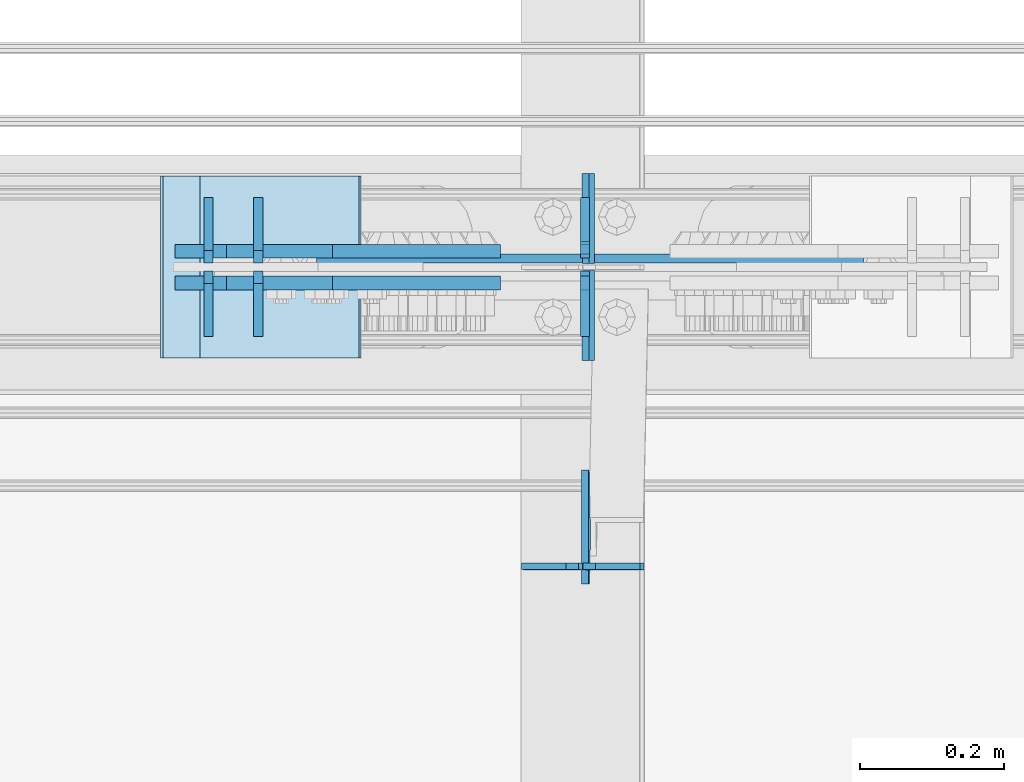
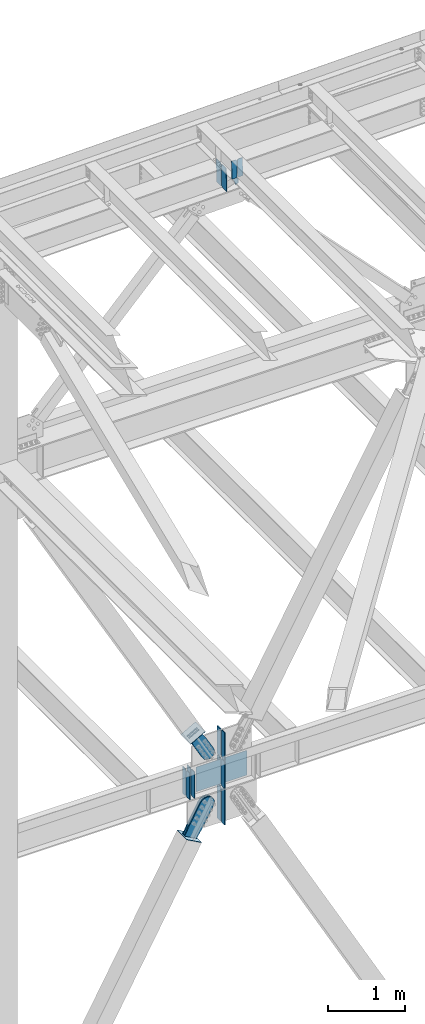
# One storey, part 3482 of 3843: 22 plates, 9 elements without a shape of their own.
"""IFC2X3 building model written with IfcOpenShell, lengths in millimetres."""

from ifc_helpers import new_model, si_unit, frame, origin_with_axes, place, context, subcontext, project, spatial, faceted_brep, material, type_object, element, aggregate, save


model = new_model("IFC2X3")

# Units and contexts
model_context = context("Model", 3, precision=1e-05, world=origin_with_axes())
body_context = subcontext(model_context, "Body", "Model", "MODEL_VIEW")
ifc_project = project(units=[si_unit("LENGTHUNIT", "METRE", prefix="MILLI"), si_unit("AREAUNIT", "SQUARE_METRE"), si_unit("VOLUMEUNIT", "CUBIC_METRE"), si_unit("MASSUNIT", "GRAM", prefix="KILO"), si_unit("TIMEUNIT", "SECOND"), si_unit("PLANEANGLEUNIT", "RADIAN"), si_unit("SOLIDANGLEUNIT", "STERADIAN"), si_unit("THERMODYNAMICTEMPERATUREUNIT", "DEGREE_CELSIUS"), si_unit("LUMINOUSINTENSITYUNIT", "LUMEN")], contexts=[model_context])

# Site, building, storey
site_placement = place(None, origin_with_axes())
site = spatial("IfcSite", under=ifc_project, at=site_placement, CompositionType="ELEMENT")
building_placement = place(site_placement, origin_with_axes())
building = spatial("IfcBuilding", under=site, at=building_placement, Name="Undefined", CompositionType="ELEMENT")
storey_placement = place(building_placement, origin_with_axes())
storey = spatial("IfcBuildingStorey", under=building, at=storey_placement, Name="Undefined", CompositionType="ELEMENT", Elevation=0.0)

# Assembly, plates
assembly_1_placement = place(storey_placement, origin_with_axes())
assembly_1 = element("IfcElementAssembly", 1, at=assembly_1_placement, inside=storey, Name="BEAM", AssemblyPlace="NOTDEFINED", PredefinedType="RIGID_FRAME")
ifc_material_1 = material(Name="STEEL/A572-50")
plate_type_1 = type_object("IfcPlateType", PredefinedType="NOTDEFINED")
plate_1_placement = place(assembly_1_placement, frame((59291.994738493, 92084.525, 45502.009667302), z_axis=(-0.0211520980073474, 0.0, 0.999776269347241), x_axis=(0.0, 1.0, 0.0)))
plate_1 = element("IfcPlate", 2, at=plate_1_placement, type_object=plate_type_1, material=ifc_material_1, Name="STIFFENER", context=body_context, shape_type="Brep", body=[
    faceted_brep([(0.0, -4.76249999999709, 0.0), (0.0, -4.76249999999709, 377.824999997538), (0.0, 4.76249999999709, 377.824999997538), (0.0, 4.76249999999709, 0.0), (103.187499618536, -4.76249999999709, 377.824999997538), (103.187499618536, 4.76249999999709, 377.824999997538), (125.412500000006, -4.76249999999709, 355.599999616068), (125.412500000006, 4.76249999999709, 355.599999616068), (125.412500000006, -4.76249999999709, 22.2250003814697), (125.412500000006, 4.76249999999709, 22.2250003814697), (103.187499618536, -4.76249999999709, 0.0), (103.187499618536, 4.76249999999709, 0.0)], [[[0, 1, 2, 3]], [[1, 4, 5, 2]], [[4, 6, 7, 5]], [[6, 8, 9, 7]], [[8, 10, 11, 9]], [[10, 0, 3, 11]], [[5, 7, 9, 11, 3, 2]], [[10, 8, 6, 4, 1, 0]]]),
])
plate_2_placement = place(assembly_1_placement, frame((59291.994738493, 92219.4625, 45502.009667302), z_axis=(-0.0211520980073474, 0.0, 0.999776269347241), x_axis=(0.0, 1.0, 0.0)))
plate_2 = element("IfcPlate", 3, at=plate_2_placement, type_object=plate_type_1, material=ifc_material_1, Name="STIFFENER", context=body_context, shape_type="Brep", body=[
    faceted_brep([(0.0, -4.76249999999709, 22.2250003814697), (0.0, -4.76249999999709, 355.599999616068), (0.0, 4.76249999999709, 355.599999616068), (0.0, 4.76249999999709, 22.2250003814697), (22.2250003814697, -4.76249999999709, 377.824999997538), (22.2250003814697, 4.76249999999709, 377.824999997538), (125.412500000006, -4.76249999999709, 377.824999997538), (125.412500000006, 4.76249999999709, 377.824999997538), (125.412500000006, -4.76249999999709, 0.0), (125.412500000006, 4.76249999999709, 0.0), (22.2250003814697, -4.76249999999709, 0.0), (22.2250003814697, 4.76249999999709, 0.0)], [[[0, 1, 2, 3]], [[1, 4, 5, 2]], [[4, 6, 7, 5]], [[6, 8, 9, 7]], [[8, 10, 11, 9]], [[10, 0, 3, 11]], [[5, 7, 9, 11, 3, 2]], [[10, 8, 6, 4, 1, 0]]]),
])
aggregate(assembly_1, [plate_1, plate_2])

assembly_2_placement = place(storey_placement, origin_with_axes())
assembly_2 = element("IfcElementAssembly", 4, at=assembly_2_placement, inside=storey, Name="BEAM", AssemblyPlace="NOTDEFINED", PredefinedType="RIGID_FRAME")
plate_type_2 = type_object("IfcPlateType", PredefinedType="NOTDEFINED")
plate_3_placement = place(assembly_2_placement, frame((58758.8797832198, 92220.25625, 35990.2125), z_axis=(0.0, 1.0, 0.0), x_axis=(0.0, 0.0, 1.0)))
plate_3 = element("IfcPlate", 5, at=plate_3_placement, type_object=plate_type_2, material=ifc_material_1, Name="CB_BEAM", context=body_context, shape_type="Brep", body=[
    faceted_brep([(0.0, -6.34999999999854, 17.4624996185303), (0.0, -6.34999999999854, 91.28125), (0.0, 6.34999999999854, 91.28125), (0.0, 6.34999999999854, 17.4624996185303), (425.449999999997, -6.34999999999854, 91.28125), (425.449999999997, 6.34999999999854, 91.28125), (425.449999999997, -6.34999999999854, 17.4624996185303), (425.449999999997, 6.34999999999854, 17.4624996185303), (407.987500381467, -6.34999999999854, 0.0), (407.987500381467, 6.34999999999854, 0.0), (17.4624996185303, -6.34999999999854, 0.0), (17.4624996185303, 6.34999999999854, 0.0)], [[[0, 1, 2, 3]], [[1, 4, 5, 2]], [[4, 6, 7, 5]], [[6, 8, 9, 7]], [[8, 10, 11, 9]], [[10, 0, 3, 11]], [[5, 7, 9, 11, 3, 2]], [[10, 8, 6, 4, 1, 0]]]),
])
plate_4_placement = place(assembly_2_placement, frame((58758.8797832198, 92209.14375, 35990.2125), z_axis=(0.0, -1.0, 0.0), x_axis=(0.0, 0.0, 1.0)))
plate_4 = element("IfcPlate", 6, at=plate_4_placement, type_object=plate_type_2, material=ifc_material_1, Name="CB_BEAM", context=body_context, shape_type="Brep", body=[
    faceted_brep([(0.0, -6.34999999999854, 17.4624996185303), (0.0, -6.34999999999854, 91.28125), (0.0, 6.34999999999854, 91.28125), (0.0, 6.34999999999854, 17.4624996185303), (425.449999999997, -6.34999999999854, 91.28125), (425.449999999997, 6.34999999999854, 91.28125), (425.449999999997, -6.34999999999854, 17.4624996185303), (425.449999999997, 6.34999999999854, 17.4624996185303), (407.987500381467, -6.34999999999854, 0.0), (407.987500381467, 6.34999999999854, 0.0), (17.4624996185303, -6.34999999999854, 0.0), (17.4624996185303, 6.34999999999854, 0.0)], [[[0, 1, 2, 3]], [[1, 4, 5, 2]], [[4, 6, 7, 5]], [[6, 8, 9, 7]], [[8, 10, 11, 9]], [[10, 0, 3, 11]], [[5, 7, 9, 11, 3, 2]], [[10, 8, 6, 4, 1, 0]]]),
])
plate_5_placement = place(assembly_2_placement, frame((58828.0666674803, 92220.25625, 35990.2125), z_axis=(0.0, 1.0, 0.0), x_axis=(0.0, 0.0, 1.0)))
plate_5 = element("IfcPlate", 7, at=plate_5_placement, type_object=plate_type_2, material=ifc_material_1, Name="CB_BEAM", context=body_context, shape_type="Brep", body=[
    faceted_brep([(0.0, -6.34999999999854, 17.4624996185303), (0.0, -6.34999999999854, 91.28125), (0.0, 6.34999999999854, 91.28125), (0.0, 6.34999999999854, 17.4624996185303), (425.449999999997, -6.34999999999854, 91.28125), (425.449999999997, 6.34999999999854, 91.28125), (425.449999999997, -6.34999999999854, 17.4624996185303), (425.449999999997, 6.34999999999854, 17.4624996185303), (407.987500381467, -6.34999999999854, 0.0), (407.987500381467, 6.34999999999854, 0.0), (17.4624996185303, -6.34999999999854, 0.0), (17.4624996185303, 6.34999999999854, 0.0)], [[[0, 1, 2, 3]], [[1, 4, 5, 2]], [[4, 6, 7, 5]], [[6, 8, 9, 7]], [[8, 10, 11, 9]], [[10, 0, 3, 11]], [[5, 7, 9, 11, 3, 2]], [[10, 8, 6, 4, 1, 0]]]),
])
plate_6_placement = place(assembly_2_placement, frame((58828.0666674803, 92209.14375, 35990.2125), z_axis=(0.0, -1.0, 0.0), x_axis=(0.0, 0.0, 1.0)))
plate_6 = element("IfcPlate", 8, at=plate_6_placement, type_object=plate_type_2, material=ifc_material_1, Name="CB_BEAM", context=body_context, shape_type="Brep", body=[
    faceted_brep([(0.0, -6.34999999999854, 17.4624996185303), (0.0, -6.34999999999854, 91.28125), (0.0, 6.34999999999854, 91.28125), (0.0, 6.34999999999854, 17.4624996185303), (425.449999999997, -6.34999999999854, 91.28125), (425.449999999997, 6.34999999999854, 91.28125), (425.449999999997, -6.34999999999854, 17.4624996185303), (425.449999999997, 6.34999999999854, 17.4624996185303), (407.987500381467, -6.34999999999854, 0.0), (407.987500381467, 6.34999999999854, 0.0), (17.4624996185303, -6.34999999999854, 0.0), (17.4624996185303, 6.34999999999854, 0.0)], [[[0, 1, 2, 3]], [[1, 4, 5, 2]], [[4, 6, 7, 5]], [[6, 8, 9, 7]], [[8, 10, 11, 9]], [[10, 0, 3, 11]], [[5, 7, 9, 11, 3, 2]], [[10, 8, 6, 4, 1, 0]]]),
])
plate_7_placement = place(assembly_2_placement, frame((59283.6000023894, 92209.14375, 35990.2125), z_axis=(0.0, -1.0, 0.0), x_axis=(0.0, 0.0, 1.0)))
plate_7 = element("IfcPlate", 9, at=plate_7_placement, type_object=plate_type_2, material=ifc_material_1, Name="CB_BEAM", context=body_context, shape_type="Brep", body=[
    faceted_brep([(0.0, -6.34999999999854, 17.4624996185303), (0.0, -6.34999999999854, 91.28125), (0.0, 6.34999999999854, 91.28125), (0.0, 6.34999999999854, 17.4624996185303), (425.449999999997, -6.34999999999854, 91.28125), (425.449999999997, 6.34999999999854, 91.28125), (425.449999999997, -6.34999999999854, 17.4624996185303), (425.449999999997, 6.34999999999854, 17.4624996185303), (407.987500381467, -6.34999999999854, 0.0), (407.987500381467, 6.34999999999854, 0.0), (17.4624996185303, -6.34999999999854, 0.0), (17.4624996185303, 6.34999999999854, 0.0)], [[[0, 1, 2, 3]], [[1, 4, 5, 2]], [[4, 6, 7, 5]], [[6, 8, 9, 7]], [[8, 10, 11, 9]], [[10, 0, 3, 11]], [[5, 7, 9, 11, 3, 2]], [[10, 8, 6, 4, 1, 0]]]),
])
plate_type_3 = type_object("IfcPlateType", PredefinedType="NOTDEFINED")
plate_8_placement = place(assembly_2_placement, frame((58909.4207420616, 92226.6062499984, 36006.0874996181), z_axis=(0.0, 0.0, 1.0), x_axis=(1.0, 0.0, 0.0)))
plate_8 = element("IfcPlate", 10, at=plate_8_placement, type_object=plate_type_3, material=ifc_material_1, Name="PLATE", context=body_context, shape_type="Brep", body=[
    faceted_brep([(0.0, -6.3499999046162, 0.0), (0.0, 6.35000000000582, 7.33234923778218), (761.999999999964, 6.35000000000582, 7.33234923778218), (761.999999999964, -6.35000000000582, 4.22005541622639e-10), (761.999999999978, -6.35000000000582, 393.700000763354), (0.0, -6.34999999999854, 393.700012207031), (1.45519152283669e-11, 6.35000000000582, 386.367651525979), (761.999999999978, 6.35000000000582, 386.367651525979)], [[[0, 1, 2, 3]], [[0, 3, 4, 5]], [[1, 0, 5, 6]], [[2, 1, 6, 7]], [[3, 2, 7, 4]], [[6, 5, 4, 7]]]),
])

# Assembly, plate
assembly_3_placement = place(storey_placement, origin_with_axes())
assembly_3 = element("IfcElementAssembly", 11, at=assembly_3_placement, inside=storey, AssemblyPlace="NOTDEFINED", PredefinedType="RIGID_FRAME")
ifc_material_2 = material(Name="STEEL/A36")
plate_type_4 = type_object("IfcPlateType", PredefinedType="NOTDEFINED")
plate_9_placement = place(assembly_3_placement, frame((58931.1760921193, 92236.925, 37006.2349786078), z_axis=(-0.872780312308932, 0.0, -0.488113231172771), x_axis=(0.488113231172773, 0.0, -0.872780312308931)))
plate_9 = element("IfcPlate", 12, at=plate_9_placement, type_object=plate_type_4, material=ifc_material_2, context=body_context, shape_type="Brep", body=[
    faceted_brep([(0.0, -9.52500000000146, 0.0), (-2.16823536902666e-09, -9.52499999999418, 169.022957228546), (-2.16823536902666e-09, 9.52499999999418, 169.022957228546), (0.0, 9.52500000000146, 0.0), (69.8499999974956, -9.52499999999418, 169.02295722875), (69.8499999974956, 9.52499999999418, 169.02295722875), (171.449999996829, -9.52499999999418, 181.348978614493), (171.449999996829, 9.52499999999418, 181.348978614493), (434.579297661258, -9.52499999999418, 181.348978615235), (434.579297661258, 9.52499999999418, 181.348978615235), (471.63740512668, -9.52499999999418, 173.977662728823), (471.63740512668, 9.52499999999418, 173.977662728823), (503.053751663178, -9.52499999999418, 152.985931091971), (503.053751663178, 9.52499999999418, 152.985931091971), (524.045483300536, -9.52499999999418, 121.569584555793), (524.045483300536, 9.52499999999418, 121.569584555793), (531.416799187516, -9.52499999999418, 84.511480142959), (531.416799187516, 9.52499999999418, 84.511480142959), (524.0454833013, -9.52499999999418, 47.4533726770169), (524.0454833013, 9.52499999999418, 47.4533726770169), (503.053751664252, -9.52499999999418, 16.0370261400676), (503.053751664252, 9.52499999999418, 16.0370261400676), (471.63740512763, -9.52499999999418, -4.95470549746824), (471.63740512763, 9.52499999999418, -4.95470549746824), (434.579299189239, -9.52499999999418, -12.3260213842586), (434.579299189239, 9.52499999999418, -12.3260213842586), (171.44999999931, -9.52499999999418, -12.3260213849862), (171.44999999931, 9.52499999999418, -12.3260213849862), (69.8499999979995, -9.52499999999418, -4.00177668780088e-10), (69.8499999979995, 9.52499999999418, -4.00177668780088e-10)], [[[0, 1, 2, 3]], [[1, 4, 5, 2]], [[4, 6, 7, 5]], [[6, 8, 9, 7]], [[8, 10, 11, 9]], [[10, 12, 13, 11]], [[12, 14, 15, 13]], [[14, 16, 17, 15]], [[16, 18, 19, 17]], [[18, 20, 21, 19]], [[20, 22, 23, 21]], [[22, 24, 25, 23]], [[24, 26, 27, 25]], [[26, 28, 29, 27]], [[28, 0, 3, 29]], [[5, 7, 9, 11, 13, 15, 17, 19, 21, 23, 25, 27, 29, 3, 2]], [[28, 26, 24, 22, 20, 18, 16, 14, 12, 10, 8, 6, 4, 1, 0]]]),
])
aggregate(assembly_3, [plate_9])

assembly_4_placement = place(storey_placement, origin_with_axes())
assembly_4 = element("IfcElementAssembly", 13, at=assembly_4_placement, inside=storey, AssemblyPlace="NOTDEFINED", PredefinedType="RIGID_FRAME")
plate_10_placement = place(assembly_4_placement, frame((58931.1760921193, 92192.475, 37006.2349786078), z_axis=(-0.872780312308932, 0.0, -0.488113231172771), x_axis=(0.488113231172773, 0.0, -0.872780312308931)))
plate_10 = element("IfcPlate", 14, at=plate_10_placement, type_object=plate_type_4, material=ifc_material_2, context=body_context, shape_type="Brep", body=[
    faceted_brep([(0.0, -9.52500000000146, 0.0), (-2.16823536902666e-09, -9.52499999999418, 169.022957228546), (-2.16823536902666e-09, 9.52499999999418, 169.022957228546), (0.0, 9.52500000000146, 0.0), (69.8499999974956, -9.52499999999418, 169.02295722875), (69.8499999974956, 9.52499999999418, 169.02295722875), (171.449999996829, -9.52499999999418, 181.348978614493), (171.449999996829, 9.52499999999418, 181.348978614493), (434.579297661258, -9.52499999999418, 181.348978615235), (434.579297661258, 9.52499999999418, 181.348978615235), (471.63740512668, -9.52499999999418, 173.977662728823), (471.63740512668, 9.52499999999418, 173.977662728823), (503.053751663178, -9.52499999999418, 152.985931091971), (503.053751663178, 9.52499999999418, 152.985931091971), (524.045483300536, -9.52499999999418, 121.569584555793), (524.045483300536, 9.52499999999418, 121.569584555793), (531.416799187516, -9.52499999999418, 84.511480142959), (531.416799187516, 9.52499999999418, 84.511480142959), (524.0454833013, -9.52499999999418, 47.4533726770169), (524.0454833013, 9.52499999999418, 47.4533726770169), (503.053751664252, -9.52499999999418, 16.0370261400676), (503.053751664252, 9.52499999999418, 16.0370261400676), (471.63740512763, -9.52499999999418, -4.95470549746824), (471.63740512763, 9.52499999999418, -4.95470549746824), (434.579299189239, -9.52499999999418, -12.3260213842586), (434.579299189239, 9.52499999999418, -12.3260213842586), (171.44999999931, -9.52499999999418, -12.3260213849862), (171.44999999931, 9.52499999999418, -12.3260213849862), (69.8499999979995, -9.52499999999418, -4.00177668780088e-10), (69.8499999979995, 9.52499999999418, -4.00177668780088e-10)], [[[0, 1, 2, 3]], [[1, 4, 5, 2]], [[4, 6, 7, 5]], [[6, 8, 9, 7]], [[8, 10, 11, 9]], [[10, 12, 13, 11]], [[12, 14, 15, 13]], [[14, 16, 17, 15]], [[16, 18, 19, 17]], [[18, 20, 21, 19]], [[20, 22, 23, 21]], [[22, 24, 25, 23]], [[24, 26, 27, 25]], [[26, 28, 29, 27]], [[28, 0, 3, 29]], [[5, 7, 9, 11, 13, 15, 17, 19, 21, 23, 25, 27, 29, 3, 2]], [[28, 26, 24, 22, 20, 18, 16, 14, 12, 10, 8, 6, 4, 1, 0]]]),
])
aggregate(assembly_4, [plate_10])

assembly_5_placement = place(storey_placement, origin_with_axes())
assembly_5 = element("IfcElementAssembly", 15, at=assembly_5_placement, inside=storey, Name="Plate", AssemblyPlace="NOTDEFINED", PredefinedType="RIGID_FRAME")
plate_type_5 = type_object("IfcPlateType", PredefinedType="NOTDEFINED")
plate_11_placement = place(assembly_5_placement, frame((58748.1227972154, 92341.7, 36900.2223498337), z_axis=(0.872780312308932, 0.0, 0.488113231172771), x_axis=(0.0, -1.0, 0.0)))
plate_11 = element("IfcPlate", 16, at=plate_11_placement, type_object=plate_type_5, material=ifc_material_2, Name="Plate", context=body_context, shape_type="Brep", body=[
    faceted_brep([(0.0, -3.17499999999927, 0.0), (0.0, -3.17499999965185, 254.000000005151), (0.0, 3.17500000035216, 254.000000005166), (0.0, 3.17499999999927, 0.0), (254.0, -3.17499999965185, 254.000000005151), (254.0, 3.17500000035216, 254.000000005166), (254.0, -3.17500000000291, 0.0), (254.0, 3.17499999999927, 1.45519152283669e-11)], [[[0, 1, 2, 3]], [[1, 4, 5, 2]], [[4, 6, 7, 5]], [[6, 0, 3, 7]], [[5, 7, 3, 2]], [[6, 4, 1, 0]]]),
])
aggregate(assembly_5, [plate_11])

assembly_6_placement = place(storey_placement, origin_with_axes())
assembly_6 = element("IfcElementAssembly", 17, at=assembly_6_placement, inside=storey, Name="Plate", AssemblyPlace="NOTDEFINED", PredefinedType="RIGID_FRAME")
plate_12_placement = place(assembly_6_placement, frame((58915.6084846022, 92087.7, 35276.4579874361), z_axis=(-0.874773404023983, 0.0, 0.484532240013287), x_axis=(0.0, 1.0, 0.0)))
plate_12 = element("IfcPlate", 18, at=plate_12_placement, type_object=plate_type_5, material=ifc_material_2, Name="Plate", context=body_context, shape_type="Brep", body=[
    faceted_brep([(0.0, -3.17499999999927, 0.0), (0.0, -3.17499999965185, 254.000000005151), (0.0, 3.17500000035216, 254.000000005166), (0.0, 3.17499999999927, 0.0), (254.0, -3.17499999965185, 254.000000005151), (254.0, 3.17500000035216, 254.000000005166), (254.0, -3.17500000000291, 0.0), (254.0, 3.17499999999927, 1.45519152283669e-11)], [[[0, 1, 2, 3]], [[1, 4, 5, 2]], [[4, 6, 7, 5]], [[6, 0, 3, 7]], [[5, 7, 3, 2]], [[6, 4, 1, 0]]]),
])
aggregate(assembly_6, [plate_12])

# Plate
plate_type_6 = type_object("IfcPlateType", PredefinedType="NOTDEFINED")
plate_13_placement = place(assembly_2_placement, frame((59283.6000023894, 92227.4, 35408.39375), z_axis=(0.0, 1.0, 0.0), x_axis=(0.0, 0.0, 1.0)))
plate_13 = element("IfcPlate", 19, at=plate_13_placement, type_object=plate_type_6, material=ifc_material_1, Name="CB", context=body_context, shape_type="Brep", body=[
    faceted_brep([(0.0, -6.3499999046162, 0.0), (0.0, -6.34999999999854, 84.1374999999971), (0.0, 6.34999999999854, 84.1374999999971), (7.27595761418343e-12, 6.3499999046162, 0.0), (560.476092697543, -6.34999999999854, 84.1374999999971), (560.476092697543, 6.34999999999854, 84.1374999999971), (560.476092697543, -6.34999999999854, 19.0499992370605), (560.476092697543, 6.34999999999854, 19.0499992370605), (541.426093460483, -6.34999999999854, 0.0), (541.426093460483, 6.34999999999854, 0.0)], [[[0, 1, 2, 3]], [[1, 4, 5, 2]], [[4, 6, 7, 5]], [[6, 8, 9, 7]], [[8, 0, 3, 9]], [[5, 7, 9, 3, 2]], [[8, 6, 4, 1, 0]]]),
])

plate_14_placement = place(assembly_2_placement, frame((59283.6000023894, 92202.0, 35408.39375), z_axis=(0.0, -1.0, 0.0), x_axis=(0.0, 0.0, 1.0)))
plate_14 = element("IfcPlate", 20, at=plate_14_placement, type_object=plate_type_6, material=ifc_material_1, Name="CB", context=body_context, shape_type="Brep", body=[
    faceted_brep([(0.0, -6.3499999046162, 0.0), (0.0, -6.34999999999854, 84.1374999999971), (0.0, 6.34999999999854, 84.1374999999971), (7.27595761418343e-12, 6.3499999046162, 0.0), (560.476092697543, -6.34999999999854, 84.1374999999971), (560.476092697543, 6.34999999999854, 84.1374999999971), (560.476092697543, -6.34999999999854, 19.0499992370605), (560.476092697543, 6.34999999999854, 19.0499992370605), (541.426093460483, -6.34999999999854, 0.0), (541.426093460483, 6.34999999999854, 0.0)], [[[0, 1, 2, 3]], [[1, 4, 5, 2]], [[4, 6, 7, 5]], [[6, 8, 9, 7]], [[8, 0, 3, 9]], [[5, 7, 9, 3, 2]], [[8, 6, 4, 1, 0]]]),
])

plate_15_placement = place(assembly_2_placement, frame((59283.6000023894, 92227.4, 36436.3), z_axis=(0.0, 1.0, 0.0), x_axis=(0.0, 0.0, 1.0)))
plate_15 = element("IfcPlate", 21, at=plate_15_placement, type_object=plate_type_6, material=ifc_material_1, Name="CB", context=body_context, shape_type="Brep", body=[
    faceted_brep([(0.0, -6.34999999999854, 19.0499992370605), (0.0, -6.34999999999854, 84.1374999999971), (0.0, 6.34999999999854, 84.1374999999971), (0.0, 6.34999999999854, 19.0499992370605), (438.71136425755, -6.34999999999854, 84.1374999999971), (438.71136425755, 6.34999999999854, 84.1374999999971), (438.71136425755, -6.34999999999854, 0.0), (438.71136425755, 6.34999999999854, 0.0), (19.0499992370605, -6.34999999999854, 0.0), (19.0499992370605, 6.34999999999854, 0.0)], [[[0, 1, 2, 3]], [[1, 4, 5, 2]], [[4, 6, 7, 5]], [[6, 8, 9, 7]], [[8, 0, 3, 9]], [[5, 7, 9, 3, 2]], [[8, 6, 4, 1, 0]]]),
])

plate_16_placement = place(assembly_2_placement, frame((59283.6000023894, 92202.0, 36436.3), z_axis=(0.0, -1.0, 0.0), x_axis=(0.0, 0.0, 1.0)))
plate_16 = element("IfcPlate", 22, at=plate_16_placement, type_object=plate_type_6, material=ifc_material_1, Name="CB", context=body_context, shape_type="Brep", body=[
    faceted_brep([(0.0, -6.34999999999854, 19.0499992370605), (0.0, -6.34999999999854, 84.1374999999971), (0.0, 6.34999999999854, 84.1374999999971), (0.0, 6.34999999999854, 19.0499992370605), (438.71136425755, -6.34999999999854, 84.1374999999971), (438.71136425755, 6.34999999999854, 84.1374999999971), (438.71136425755, -6.34999999999854, 0.0), (438.71136425755, 6.34999999999854, 0.0), (19.0499992370605, -6.34999999999854, 0.0), (19.0499992370605, 6.34999999999854, 0.0)], [[[0, 1, 2, 3]], [[1, 4, 5, 2]], [[4, 6, 7, 5]], [[6, 8, 9, 7]], [[8, 0, 3, 9]], [[5, 7, 9, 3, 2]], [[8, 6, 4, 1, 0]]]),
])

# Assembly, plate
assembly_7_placement = place(storey_placement, origin_with_axes())
assembly_7 = element("IfcElementAssembly", 23, at=assembly_7_placement, inside=storey, AssemblyPlace="NOTDEFINED", PredefinedType="RIGID_FRAME")
plate_type_7 = type_object("IfcPlateType", PredefinedType="NOTDEFINED")
plate_17_placement = place(assembly_7_placement, frame((58893.9444834141, 92236.925, 35284.8280487394), z_axis=(-0.874773404023983, 0.0, 0.484532240013287), x_axis=(0.484532240013288, 0.0, 0.874773404023982)))
plate_17 = element("IfcPlate", 24, at=plate_17_placement, type_object=plate_type_7, material=ifc_material_2, context=body_context, shape_type="Brep", body=[
    faceted_brep([(0.0, -9.52500000000146, 0.0), (-1.45519152283669e-11, -9.52499999999418, 207.986686767843), (-1.45519152283669e-11, 9.52499999999418, 207.986686767843), (0.0, 9.52500000000146, 0.0), (69.8499999996129, -9.52499999999418, 207.986686767857), (69.8499999996129, 9.52499999999418, 207.986686767857), (171.449999999044, -9.52499999999418, 216.705843383315), (171.449999999044, 9.52499999999418, 216.705843383315), (511.019864338588, -9.52499999999418, 216.705843383315), (511.019864338588, 9.52499999999418, 216.705843383315), (554.153071292923, -9.52499999999418, 208.126115075342), (554.153071292923, 9.52499999999418, 208.126115075342), (590.719638491966, -9.52499999999418, 183.693116010902), (590.719638491966, 9.52499999999418, 183.693116010902), (615.152637556399, -9.52499999999418, 147.126548811866), (615.152637556399, 9.52499999999418, 147.126548811866), (623.732365864373, -9.52499999999418, 103.993344910348), (623.732365864373, 9.52499999999418, 103.993344910348), (615.152637556399, -9.52499999999418, 60.8601379559914), (615.152637556399, 9.52499999999418, 60.8601379559914), (590.719638491966, -9.52499999999418, 24.2935707569559), (590.719638491966, 9.52499999999418, 24.2935707569559), (554.153071292923, -9.52499999999418, -0.139428307476919), (554.153071292923, 9.52499999999418, -0.139428307476919), (511.01986586499, -9.52499999999418, -8.71915661544335), (511.01986586499, 9.52499999999418, -8.71915661544335), (171.449999999051, -9.52499999999418, -8.71915661547246), (171.449999999051, 9.52499999999418, -8.71915661547246), (69.8499999979995, -9.52499999999418, -4.00177668780088e-10), (69.8499999979995, 9.52499999999418, -4.00177668780088e-10)], [[[0, 1, 2, 3]], [[1, 4, 5, 2]], [[4, 6, 7, 5]], [[6, 8, 9, 7]], [[8, 10, 11, 9]], [[10, 12, 13, 11]], [[12, 14, 15, 13]], [[14, 16, 17, 15]], [[16, 18, 19, 17]], [[18, 20, 21, 19]], [[20, 22, 23, 21]], [[22, 24, 25, 23]], [[24, 26, 27, 25]], [[26, 28, 29, 27]], [[28, 0, 3, 29]], [[5, 7, 9, 11, 13, 15, 17, 19, 21, 23, 25, 27, 29, 3, 2]], [[28, 26, 24, 22, 20, 18, 16, 14, 12, 10, 8, 6, 4, 1, 0]]]),
])
aggregate(assembly_7, [plate_17])

assembly_8_placement = place(storey_placement, origin_with_axes())
assembly_8 = element("IfcElementAssembly", 25, at=assembly_8_placement, inside=storey, AssemblyPlace="NOTDEFINED", PredefinedType="RIGID_FRAME")
plate_18_placement = place(assembly_8_placement, frame((58893.9444834141, 92192.475, 35284.8280487394), z_axis=(-0.874773404023983, 0.0, 0.484532240013287), x_axis=(0.484532240013288, 0.0, 0.874773404023982)))
plate_18 = element("IfcPlate", 26, at=plate_18_placement, type_object=plate_type_7, material=ifc_material_2, context=body_context, shape_type="Brep", body=[
    faceted_brep([(0.0, -9.52500000000146, 0.0), (-1.45519152283669e-11, -9.52499999999418, 207.986686767843), (-1.45519152283669e-11, 9.52499999999418, 207.986686767843), (0.0, 9.52500000000146, 0.0), (69.8499999996129, -9.52499999999418, 207.986686767857), (69.8499999996129, 9.52499999999418, 207.986686767857), (171.449999999044, -9.52499999999418, 216.705843383315), (171.449999999044, 9.52499999999418, 216.705843383315), (511.019864338588, -9.52499999999418, 216.705843383315), (511.019864338588, 9.52499999999418, 216.705843383315), (554.153071292923, -9.52499999999418, 208.126115075342), (554.153071292923, 9.52499999999418, 208.126115075342), (590.719638491966, -9.52499999999418, 183.693116010902), (590.719638491966, 9.52499999999418, 183.693116010902), (615.152637556399, -9.52499999999418, 147.126548811866), (615.152637556399, 9.52499999999418, 147.126548811866), (623.732365864373, -9.52499999999418, 103.993344910348), (623.732365864373, 9.52499999999418, 103.993344910348), (615.152637556399, -9.52499999999418, 60.8601379559914), (615.152637556399, 9.52499999999418, 60.8601379559914), (590.719638491966, -9.52499999999418, 24.2935707569559), (590.719638491966, 9.52499999999418, 24.2935707569559), (554.153071292923, -9.52499999999418, -0.139428307476919), (554.153071292923, 9.52499999999418, -0.139428307476919), (511.01986586499, -9.52499999999418, -8.71915661544335), (511.01986586499, 9.52499999999418, -8.71915661544335), (171.449999999051, -9.52499999999418, -8.71915661547246), (171.449999999051, 9.52499999999418, -8.71915661547246), (69.8499999979995, -9.52499999999418, -4.00177668780088e-10), (69.8499999979995, 9.52499999999418, -4.00177668780088e-10)], [[[0, 1, 2, 3]], [[1, 4, 5, 2]], [[4, 6, 7, 5]], [[6, 8, 9, 7]], [[8, 10, 11, 9]], [[10, 12, 13, 11]], [[12, 14, 15, 13]], [[14, 16, 17, 15]], [[16, 18, 19, 17]], [[18, 20, 21, 19]], [[20, 22, 23, 21]], [[22, 24, 25, 23]], [[24, 26, 27, 25]], [[26, 28, 29, 27]], [[28, 0, 3, 29]], [[5, 7, 9, 11, 13, 15, 17, 19, 21, 23, 25, 27, 29, 3, 2]], [[28, 26, 24, 22, 20, 18, 16, 14, 12, 10, 8, 6, 4, 1, 0]]]),
])
aggregate(assembly_8, [plate_18])

# Plate
plate_type_8 = type_object("IfcPlateType", PredefinedType="NOTDEFINED")
plate_19_placement = place(assembly_2_placement, frame((59283.6000023894, 92232.95625, 35990.2125), z_axis=(0.0, 1.0, 0.0), x_axis=(0.0, 0.0, 1.0)))
plate_19 = element("IfcPlate", 27, at=plate_19_placement, type_object=plate_type_8, material=ifc_material_1, Name="CB_BEAM", context=body_context, shape_type="Brep", body=[
    faceted_brep([(0.0, -6.34999999999854, 17.4624996185303), (0.0, -6.34999999999854, 78.5812500000029), (0.0, 6.34999999999854, 78.5812500000029), (0.0, 6.34999999999854, 17.4624996185303), (425.449999999997, -6.34999999999854, 78.5812500000029), (425.449999999997, 6.34999999999854, 78.5812500000029), (425.449999999997, -6.34999999999854, 17.4624996185303), (425.449999999997, 6.34999999999854, 17.4624996185303), (407.987500381467, -6.34999999999854, 0.0), (407.987500381467, 6.34999999999854, 0.0), (17.4624996185303, -6.34999999999854, 0.0), (17.4624996185303, 6.34999999999854, 0.0)], [[[0, 1, 2, 3]], [[1, 4, 5, 2]], [[4, 6, 7, 5]], [[6, 8, 9, 7]], [[8, 10, 11, 9]], [[10, 0, 3, 11]], [[5, 7, 9, 11, 3, 2]], [[10, 8, 6, 4, 1, 0]]]),
])

aggregate(assembly_2, [plate_3, plate_4, plate_5, plate_6, plate_8, plate_19, plate_7, plate_13, plate_14, plate_15, plate_16])

# Assembly, plates
assembly_9_placement = place(storey_placement, origin_with_axes())
assembly_9 = element("IfcElementAssembly", 28, at=assembly_9_placement, inside=storey, Name="BEAM", AssemblyPlace="NOTDEFINED", PredefinedType="RIGID_FRAME")
plate_type_9 = type_object("IfcPlateType", PredefinedType="NOTDEFINED")
plate_20_placement = place(assembly_9_placement, frame((59283.5766072643, 91931.8698709045, 45899.9015241437), z_axis=(-1.58400502550648e-06, -0.999999997198664, 7.48342374863565e-05), x_axis=(0.0211520979903633, -7.4850999801065e-05, -0.999776266545638)))
plate_20 = element("IfcPlate", 29, at=plate_20_placement, type_object=plate_type_9, material=ifc_material_1, Name="PLATE", context=body_context, shape_type="Brep", body=[
    faceted_brep([(0.0, -4.76249999999709, 0.0), (-2.70811142399907e-08, -4.76250000001892, 158.560384385462), (-2.71029421128333e-08, 4.76249999997526, 158.560384385535), (0.0, 4.76249999999709, 0.0), (64.4096088781662, -4.76249999980064, 158.560384271579), (64.4096088781371, 4.76250000020082, 158.560384271637), (133.163860613262, -4.76249999955326, 89.7958391816646), (133.163860613233, 4.76250000044092, 89.7958391817228), (43.3545778650005, -4.76249999985157, 3.49245965480804e-10), (43.3545778649714, 4.76250000014261, 4.36557456851006e-10)], [[[0, 1, 2, 3]], [[1, 4, 5, 2]], [[4, 6, 7, 5]], [[6, 8, 9, 7]], [[8, 0, 3, 9]], [[5, 7, 9, 3, 2]], [[8, 6, 4, 1, 0]]]),
])
plate_type_10 = type_object("IfcPlateType", PredefinedType="NOTDEFINED")
plate_21_placement = place(assembly_9_placement, frame((59365.8964783493, 91797.5185284843, 45912.9246685234), z_axis=(-0.0211520982558723, 0.0012391990004544, 0.999775501362787), x_axis=(-0.999776269341983, -2.62180000434616e-05, -0.0211520820072761)))
plate_21 = element("IfcPlate", 30, at=plate_21_placement, type_object=plate_type_10, material=ifc_material_1, Name="STIFFENER", context=body_context, shape_type="Brep", body=[
    faceted_brep([(0.0, -4.76249999999709, 0.0), (-1.22236087918282e-09, -4.76250000040454, 288.924999996525), (-1.23691279441118e-09, 4.76249999957508, 288.92499999654), (0.0, 4.76249999999709, 0.0), (61.9125003798254, -4.76250000072469, 288.924999996685), (61.9125003798108, 4.76249999925494, 288.9249999967), (79.3749999983847, -4.76250000078289, 271.462500378249), (79.3749999983775, 4.76249999919673, 271.462500378271), (79.3749999994689, -4.7625000004191, 17.4624996186758), (79.3749999994543, 4.76249999954598, 17.4624996186976), (61.9125003810623, -4.76250000030268, 1.45519152283669e-10), (61.9125003810477, 4.76249999964784, 1.60071067512035e-10)], [[[0, 1, 2, 3]], [[1, 4, 5, 2]], [[4, 6, 7, 5]], [[6, 8, 9, 7]], [[8, 10, 11, 9]], [[10, 0, 3, 11]], [[5, 7, 9, 11, 3, 2]], [[10, 8, 6, 4, 1, 0]]]),
])
plate_22_placement = place(assembly_9_placement, frame((59280.1906576599, 91797.5162809878, 45911.1114063143), z_axis=(-0.0211520982558723, 0.0012391990004544, 0.999775501362787), x_axis=(-0.999776269341983, -2.62180000434616e-05, -0.0211520820072761)))
plate_22 = element("IfcPlate", 31, at=plate_22_placement, type_object=plate_type_10, material=ifc_material_1, Name="STIFFENER", context=body_context, shape_type="Brep", body=[
    faceted_brep([(-1.45519152283669e-11, -4.76250000000073, 17.4624996184939), (-3.34694050252438e-10, -4.76250000000073, 271.462500379137), (-3.34694050252438e-10, 4.76250000000073, 271.462500379137), (-1.45519152283669e-11, 4.76250000000073, 17.4624996184939), (17.4624996182974, -4.76250000000073, 288.924999997646), (17.4624996182974, 4.76250000000073, 288.924999997646), (79.3749999983193, -4.762500000812, 288.924999996729), (79.3749999982974, 4.76249999915308, 288.924999996751), (79.3749999995416, -4.76250000040454, 1.96450855582952e-10), (79.3749999995271, 4.76249999956053, 2.11002770811319e-10), (17.4624996186321, -4.76250000000073, 7.27595761418343e-12), (17.4624996186321, 4.76250000000073, 7.27595761418343e-12)], [[[0, 1, 2, 3]], [[1, 4, 5, 2]], [[4, 6, 7, 5]], [[6, 8, 9, 7]], [[8, 10, 11, 9]], [[10, 0, 3, 11]], [[5, 7, 9, 11, 3, 2]], [[10, 8, 6, 4, 1, 0]]]),
])
aggregate(assembly_9, [plate_21, plate_22, plate_20])

save(model, "model.ifc")
